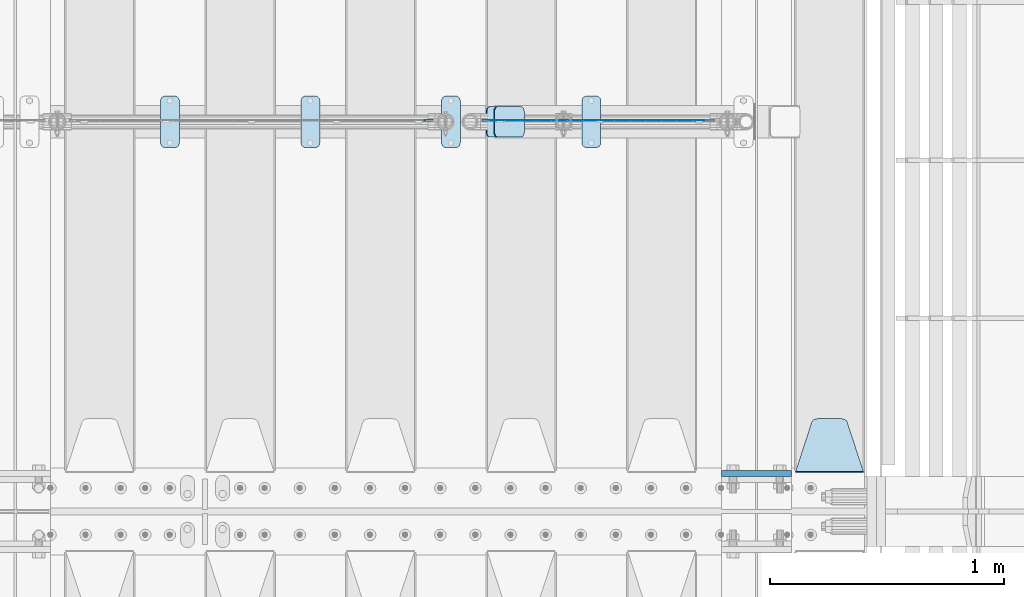
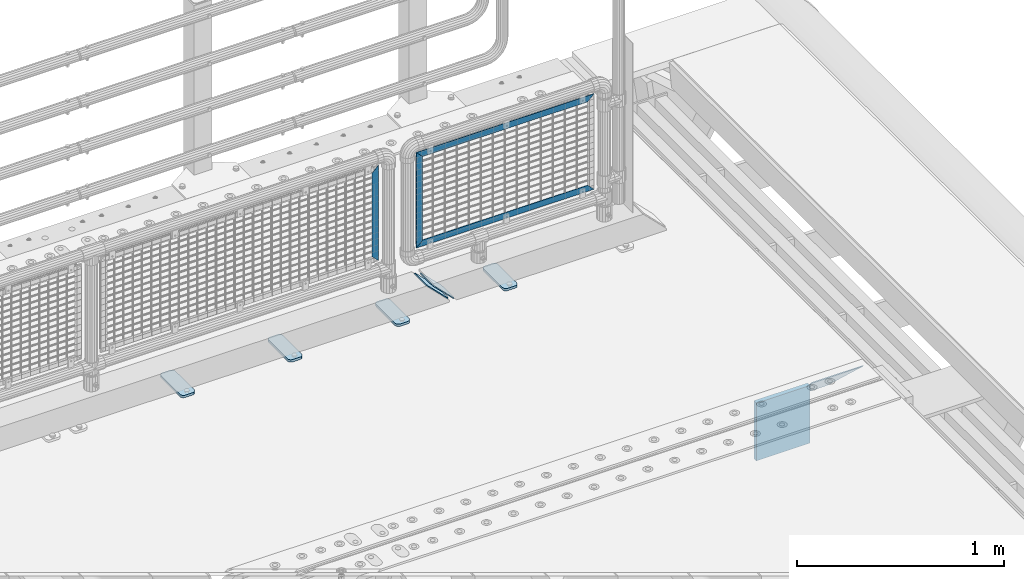
# One storey, part 222 of 240: 12 plates.
"""IFC2X3 building model written with IfcOpenShell, lengths in millimetres."""

from ifc_helpers import new_model, si_unit, frame, origin_with_axes, place, context, subcontext, project, spatial, faceted_brep, material, type_object, element, save


model = new_model("IFC2X3")

# Units and contexts
model_context = context("Model", 3, precision=1e-05, world=origin_with_axes())
body_context = subcontext(model_context, "Body", "Model", "MODEL_VIEW")
ifc_project = project(units=[si_unit("LENGTHUNIT", "METRE", prefix="MILLI"), si_unit("AREAUNIT", "SQUARE_METRE"), si_unit("VOLUMEUNIT", "CUBIC_METRE"), si_unit("MASSUNIT", "GRAM", prefix="KILO"), si_unit("TIMEUNIT", "SECOND"), si_unit("PLANEANGLEUNIT", "RADIAN"), si_unit("SOLIDANGLEUNIT", "STERADIAN"), si_unit("THERMODYNAMICTEMPERATUREUNIT", "DEGREE_CELSIUS"), si_unit("LUMINOUSINTENSITYUNIT", "LUMEN")], contexts=[model_context])

# Site, building, storey
site_placement = place(None, origin_with_axes())
site = spatial("IfcSite", under=ifc_project, at=site_placement, CompositionType="ELEMENT")
building_placement = place(site_placement, origin_with_axes())
building = spatial("IfcBuilding", under=site, at=building_placement, Name="Standard", CompositionType="ELEMENT")
storey_placement = place(building_placement, origin_with_axes())
storey = spatial("IfcBuildingStorey", under=building, at=storey_placement, Name="Undefined", CompositionType="ELEMENT", Elevation=0.0)

# Plates
ifc_material_1 = material(Name="STEEL/S355N")
plate_type_1 = type_object("IfcPlateType", PredefinedType="NOTDEFINED")
plate_1_placement = place(storey_placement, frame((55855.0, 33162.5, -340.000000000044), z_axis=(0.0, 0.0, 1.0), x_axis=(1.0, 0.0, 0.0)))
element("IfcPlate", 1, at=plate_1_placement, inside=storey, type_object=plate_type_1, material=ifc_material_1, context=body_context, shape_type="Brep", body=[
    faceted_brep([(0.0, -12.5, 0.0), (9.31322574615479e-10, -12.5, 340.0), (9.31322574615479e-10, 12.5, 340.0), (0.0, 12.5, 0.0), (300.0, -12.5, 340.0), (300.0, 12.5, 340.0), (300.0, -12.5, 0.0), (300.0, 12.5, 0.0)], [[[0, 1, 2, 3]], [[1, 4, 5, 2]], [[4, 6, 7, 5]], [[6, 0, 3, 7]], [[5, 7, 3, 2]], [[6, 4, 1, 0]]]),
])
plate_type_2 = type_object("IfcPlateType", PredefinedType="NOTDEFINED")
plate_2_placement = place(storey_placement, frame((56462.0, 33168.232233047, -1.76776695296758), z_axis=(0.0, 0.707106781186547, -0.707106781186548), x_axis=(-1.0, 0.0, 0.0)))
element("IfcPlate", 2, at=plate_2_placement, inside=storey, type_object=plate_type_2, material=ifc_material_1, context=body_context, shape_type="Brep", body=[
    faceted_brep([(0.0, -2.5, 0.0), (69.345504679477, -2.50000000000364, 300.171731424827), (69.345504679477, 2.49999999999636, 300.171731424827), (0.0, 2.5, 0.0), (70.927406119954, -2.50000000000364, 304.897442415397), (70.927406119954, 2.49999999999636, 304.897442415397), (73.3818627772271, -2.50000000000728, 309.234538108525), (73.3818627772271, 2.49999999999636, 309.234538108529), (76.6187032999587, -2.50000000000728, 313.023683126099), (76.6187032999587, 2.49999999999636, 313.023683126103), (80.5190132705029, -2.50000000000364, 316.125672595368), (80.5190132705029, 2.49999999999636, 316.125672595368), (84.9395038596849, -2.50000000000364, 318.426546230472), (84.9395038596849, 2.49999999999636, 318.426546230472), (89.7177759439219, -2.5, 319.841774983277), (89.7177759439219, 2.49999999999636, 319.841774983273), (94.6782862926484, -2.50000000000364, 320.319366455074), (94.6782862926484, 2.49999999999636, 320.319366455074), (195.321713707352, -2.50000000000364, 320.319366455074), (195.321713707352, 2.49999999999636, 320.319366455074), (200.282224056078, -2.50000000000364, 319.841774983273), (200.282224056078, 2.49999999999636, 319.841774983273), (205.060496140315, -2.50000000000364, 318.426546230472), (205.060496140315, 2.49999999999636, 318.426546230472), (209.480986729497, -2.50000000000364, 316.125672595368), (209.480986729497, 2.49999999999636, 316.125672595368), (213.381296700041, -2.50000000000728, 313.023683126099), (213.381296700041, 2.49999999999272, 313.023683126099), (216.618137222766, -2.50000000000364, 309.234538108522), (216.618137222766, 2.49999999999636, 309.234538108522), (219.072593880039, -2.50000000000364, 304.897442415397), (219.072593880039, 2.49999999999636, 304.897442415397), (220.654495320523, -2.50000000000364, 300.171731424827), (220.654495320523, 2.49999999999636, 300.171731424827), (290.0, -2.50000000000364, -3.63797880709171e-12), (290.0, 2.49999999999636, -3.63797880709171e-12)], [[[0, 1, 2, 3]], [[1, 4, 5, 2]], [[4, 6, 7, 5]], [[6, 8, 9, 7]], [[8, 10, 11, 9]], [[10, 12, 13, 11]], [[12, 14, 15, 13]], [[14, 16, 17, 15]], [[16, 18, 19, 17]], [[18, 20, 21, 19]], [[20, 22, 23, 21]], [[22, 24, 25, 23]], [[24, 26, 27, 25]], [[26, 28, 29, 27]], [[28, 30, 31, 29]], [[30, 32, 33, 31]], [[32, 34, 35, 33]], [[34, 0, 3, 35]], [[5, 7, 9, 11, 13, 15, 17, 19, 21, 23, 25, 27, 29, 31, 33, 35, 3, 2]], [[34, 32, 30, 28, 26, 24, 22, 20, 18, 16, 14, 12, 10, 8, 6, 4, 1, 0]]]),
])
ifc_material_2 = material(Name="STEEL/S355J2")
plate_type_3 = type_object("IfcPlateType", PredefinedType="NOTDEFINED")
plate_3_placement = place(storey_placement, frame((54060.0, 34774.5, 21.0199999999977), z_axis=(1.0, 0.0, 0.0), x_axis=(0.0, -1.0, 0.0)))
element("IfcPlate", 3, at=plate_3_placement, inside=storey, type_object=plate_type_3, material=ifc_material_2, context=body_context, shape_type="Brep", body=[
    faceted_brep([(0.0, -7.0, 20.0), (0.0, -7.0, 60.0), (0.0, 7.0, 60.0), (0.0, 7.0, 20.0), (0.384294391937146, -7.0, 63.9018064403208), (0.384294391937146, 7.0, 63.9018064403208), (1.52240934977453, -7.0, 67.6536686473046), (1.52240934977453, 7.0, 67.6536686473046), (3.37060775394639, -7.0, 71.1114046603907), (3.37060775394639, 7.0, 71.1114046603907), (5.85786437626666, -7.0, 74.1421356237333), (5.85786437626666, 7.0, 74.1421356237333), (8.88859533960931, -7.0, 76.6293922460536), (8.88859533960931, 7.0, 76.6293922460536), (12.3463313526954, -7.0, 78.4775906502255), (12.3463313526954, 7.0, 78.4775906502255), (16.0981935596792, -7.0, 79.6157056080629), (16.0981935596792, 7.0, 79.6157056080629), (20.0, -7.0, 80.0), (20.0, 7.0, 80.0), (200.0, -7.0, 80.0), (200.0, 7.0, 80.0), (203.901806440321, -7.0, 79.6157056080629), (203.901806440321, 7.0, 79.6157056080629), (207.653668647305, -7.0, 78.4775906502255), (207.653668647305, 7.0, 78.4775906502255), (211.111404660391, -7.0, 76.6293922460536), (211.111404660391, 7.0, 76.6293922460536), (214.142135623733, -7.0, 74.1421356237333), (214.142135623733, 7.0, 74.1421356237333), (216.629392246054, -7.0, 71.1114046603907), (216.629392246054, 7.0, 71.1114046603907), (218.477590650225, -7.0, 67.6536686473046), (218.477590650225, 7.0, 67.6536686473046), (219.615705608063, -7.0, 63.9018064403208), (219.615705608063, 7.0, 63.9018064403208), (220.0, -7.0, 60.0), (220.0, 7.0, 60.0), (220.0, -7.0, 20.0), (220.0, 7.0, 20.0), (219.615705608063, -7.0, 16.0981935596792), (219.615705608063, 7.0, 16.0981935596792), (218.477590650225, -7.0, 12.3463313526954), (218.477590650225, 7.0, 12.3463313526954), (216.629392246054, -7.0, 8.88859533960931), (216.629392246054, 7.0, 8.88859533960931), (214.142135623733, -7.0, 5.85786437626666), (214.142135623733, 7.0, 5.85786437626666), (211.111404660391, -7.0, 3.37060775394639), (211.111404660391, 7.0, 3.37060775394639), (207.653668647305, -7.0, 1.52240934977453), (207.653668647305, 7.0, 1.52240934977453), (203.901806440321, -7.0, 0.384294391937146), (203.901806440321, 7.0, 0.384294391937146), (200.0, -7.0, 0.0), (200.0, 7.0, 0.0), (20.0, -7.0, 0.0), (20.0, 7.0, 0.0), (16.0981935596792, -7.0, 0.384294391937146), (16.0981935596792, 7.0, 0.384294391937146), (12.3463313526954, -7.0, 1.52240934977453), (12.3463313526954, 7.0, 1.52240934977453), (8.88859533960931, -7.0, 3.37060775394639), (8.88859533960931, 7.0, 3.37060775394639), (5.85786437626666, -7.0, 5.85786437626666), (5.85786437626666, 7.0, 5.85786437626666), (3.37060775394639, -7.0, 8.88859533960931), (3.37060775394639, 7.0, 8.88859533960931), (1.52240934977453, -7.0, 12.3463313526954), (1.52240934977453, 7.0, 12.3463313526954), (0.384294391937146, -7.0, 16.0981935596792), (0.384294391937146, 7.0, 16.0981935596792)], [[[0, 1, 2, 3]], [[1, 4, 5, 2]], [[4, 6, 7, 5]], [[6, 8, 9, 7]], [[8, 10, 11, 9]], [[10, 12, 13, 11]], [[12, 14, 15, 13]], [[14, 16, 17, 15]], [[16, 18, 19, 17]], [[18, 20, 21, 19]], [[20, 22, 23, 21]], [[22, 24, 25, 23]], [[24, 26, 27, 25]], [[26, 28, 29, 27]], [[28, 30, 31, 29]], [[30, 32, 33, 31]], [[32, 34, 35, 33]], [[34, 36, 37, 35]], [[36, 38, 39, 37]], [[38, 40, 41, 39]], [[40, 42, 43, 41]], [[42, 44, 45, 43]], [[44, 46, 47, 45]], [[46, 48, 49, 47]], [[48, 50, 51, 49]], [[50, 52, 53, 51]], [[52, 54, 55, 53]], [[54, 56, 57, 55]], [[56, 58, 59, 57]], [[58, 60, 61, 59]], [[60, 62, 63, 61]], [[62, 64, 65, 63]], [[64, 66, 67, 65]], [[66, 68, 69, 67]], [[68, 70, 71, 69]], [[70, 0, 3, 71]], [[5, 7, 9, 11, 13, 15, 17, 19, 21, 23, 25, 27, 29, 31, 33, 35, 37, 39, 41, 43, 45, 47, 49, 51, 53, 55, 57, 59, 61, 63, 65, 67, 69, 71, 3, 2]], [[70, 68, 66, 64, 62, 60, 58, 56, 54, 52, 50, 48, 46, 44, 42, 40, 38, 36, 34, 32, 30, 28, 26, 24, 22, 20, 18, 16, 14, 12, 10, 8, 6, 4, 1, 0]]]),
])
plate_4_placement = place(storey_placement, frame((53460.0, 34774.5, 21.0199999999977), z_axis=(1.0, 0.0, 0.0), x_axis=(0.0, -1.0, 0.0)))
element("IfcPlate", 4, at=plate_4_placement, inside=storey, type_object=plate_type_3, material=ifc_material_2, context=body_context, shape_type="Brep", body=[
    faceted_brep([(0.0, -7.0, 20.0), (0.0, -7.0, 60.0), (0.0, 7.0, 60.0), (0.0, 7.0, 20.0), (0.384294391937146, -7.0, 63.9018064403208), (0.384294391937146, 7.0, 63.9018064403208), (1.52240934977453, -7.0, 67.6536686473046), (1.52240934977453, 7.0, 67.6536686473046), (3.37060775394639, -7.0, 71.1114046603907), (3.37060775394639, 7.0, 71.1114046603907), (5.85786437626666, -7.0, 74.1421356237333), (5.85786437626666, 7.0, 74.1421356237333), (8.88859533960931, -7.0, 76.6293922460536), (8.88859533960931, 7.0, 76.6293922460536), (12.3463313526954, -7.0, 78.4775906502255), (12.3463313526954, 7.0, 78.4775906502255), (16.0981935596792, -7.0, 79.6157056080629), (16.0981935596792, 7.0, 79.6157056080629), (20.0, -7.0, 80.0), (20.0, 7.0, 80.0), (200.0, -7.0, 80.0), (200.0, 7.0, 80.0), (203.901806440321, -7.0, 79.6157056080629), (203.901806440321, 7.0, 79.6157056080629), (207.653668647305, -7.0, 78.4775906502255), (207.653668647305, 7.0, 78.4775906502255), (211.111404660391, -7.0, 76.6293922460536), (211.111404660391, 7.0, 76.6293922460536), (214.142135623733, -7.0, 74.1421356237333), (214.142135623733, 7.0, 74.1421356237333), (216.629392246054, -7.0, 71.1114046603907), (216.629392246054, 7.0, 71.1114046603907), (218.477590650225, -7.0, 67.6536686473046), (218.477590650225, 7.0, 67.6536686473046), (219.615705608063, -7.0, 63.9018064403208), (219.615705608063, 7.0, 63.9018064403208), (220.0, -7.0, 60.0), (220.0, 7.0, 60.0), (220.0, -7.0, 20.0), (220.0, 7.0, 20.0), (219.615705608063, -7.0, 16.0981935596792), (219.615705608063, 7.0, 16.0981935596792), (218.477590650225, -7.0, 12.3463313526954), (218.477590650225, 7.0, 12.3463313526954), (216.629392246054, -7.0, 8.88859533960931), (216.629392246054, 7.0, 8.88859533960931), (214.142135623733, -7.0, 5.85786437626666), (214.142135623733, 7.0, 5.85786437626666), (211.111404660391, -7.0, 3.37060775394639), (211.111404660391, 7.0, 3.37060775394639), (207.653668647305, -7.0, 1.52240934977453), (207.653668647305, 7.0, 1.52240934977453), (203.901806440321, -7.0, 0.384294391937146), (203.901806440321, 7.0, 0.384294391937146), (200.0, -7.0, 0.0), (200.0, 7.0, 0.0), (20.0, -7.0, 0.0), (20.0, 7.0, 0.0), (16.0981935596792, -7.0, 0.384294391937146), (16.0981935596792, 7.0, 0.384294391937146), (12.3463313526954, -7.0, 1.52240934977453), (12.3463313526954, 7.0, 1.52240934977453), (8.88859533960931, -7.0, 3.37060775394639), (8.88859533960931, 7.0, 3.37060775394639), (5.85786437626666, -7.0, 5.85786437626666), (5.85786437626666, 7.0, 5.85786437626666), (3.37060775394639, -7.0, 8.88859533960931), (3.37060775394639, 7.0, 8.88859533960931), (1.52240934977453, -7.0, 12.3463313526954), (1.52240934977453, 7.0, 12.3463313526954), (0.384294391937146, -7.0, 16.0981935596792), (0.384294391937146, 7.0, 16.0981935596792)], [[[0, 1, 2, 3]], [[1, 4, 5, 2]], [[4, 6, 7, 5]], [[6, 8, 9, 7]], [[8, 10, 11, 9]], [[10, 12, 13, 11]], [[12, 14, 15, 13]], [[14, 16, 17, 15]], [[16, 18, 19, 17]], [[18, 20, 21, 19]], [[20, 22, 23, 21]], [[22, 24, 25, 23]], [[24, 26, 27, 25]], [[26, 28, 29, 27]], [[28, 30, 31, 29]], [[30, 32, 33, 31]], [[32, 34, 35, 33]], [[34, 36, 37, 35]], [[36, 38, 39, 37]], [[38, 40, 41, 39]], [[40, 42, 43, 41]], [[42, 44, 45, 43]], [[44, 46, 47, 45]], [[46, 48, 49, 47]], [[48, 50, 51, 49]], [[50, 52, 53, 51]], [[52, 54, 55, 53]], [[54, 56, 57, 55]], [[56, 58, 59, 57]], [[58, 60, 61, 59]], [[60, 62, 63, 61]], [[62, 64, 65, 63]], [[64, 66, 67, 65]], [[66, 68, 69, 67]], [[68, 70, 71, 69]], [[70, 0, 3, 71]], [[5, 7, 9, 11, 13, 15, 17, 19, 21, 23, 25, 27, 29, 31, 33, 35, 37, 39, 41, 43, 45, 47, 49, 51, 53, 55, 57, 59, 61, 63, 65, 67, 69, 71, 3, 2]], [[70, 68, 66, 64, 62, 60, 58, 56, 54, 52, 50, 48, 46, 44, 42, 40, 38, 36, 34, 32, 30, 28, 26, 24, 22, 20, 18, 16, 14, 12, 10, 8, 6, 4, 1, 0]]]),
])
plate_5_placement = place(storey_placement, frame((54660.0, 34774.5, 21.0199999999977), z_axis=(1.0, 0.0, 0.0), x_axis=(0.0, -1.0, 0.0)))
element("IfcPlate", 5, at=plate_5_placement, inside=storey, type_object=plate_type_3, material=ifc_material_2, context=body_context, shape_type="Brep", body=[
    faceted_brep([(0.0, -7.0, 20.0), (0.0, -7.0, 60.0), (0.0, 7.0, 60.0), (0.0, 7.0, 20.0), (0.384294391937146, -7.0, 63.9018064403208), (0.384294391937146, 7.0, 63.9018064403208), (1.52240934977453, -7.0, 67.6536686473046), (1.52240934977453, 7.0, 67.6536686473046), (3.37060775394639, -7.0, 71.1114046603907), (3.37060775394639, 7.0, 71.1114046603907), (5.85786437626666, -7.0, 74.1421356237333), (5.85786437626666, 7.0, 74.1421356237333), (8.88859533960931, -7.0, 76.6293922460536), (8.88859533960931, 7.0, 76.6293922460536), (12.3463313526954, -7.0, 78.4775906502255), (12.3463313526954, 7.0, 78.4775906502255), (16.0981935596792, -7.0, 79.6157056080629), (16.0981935596792, 7.0, 79.6157056080629), (20.0, -7.0, 80.0), (20.0, 7.0, 80.0), (200.0, -7.0, 80.0), (200.0, 7.0, 80.0), (203.901806440321, -7.0, 79.6157056080629), (203.901806440321, 7.0, 79.6157056080629), (207.653668647305, -7.0, 78.4775906502255), (207.653668647305, 7.0, 78.4775906502255), (211.111404660391, -7.0, 76.6293922460536), (211.111404660391, 7.0, 76.6293922460536), (214.142135623733, -7.0, 74.1421356237333), (214.142135623733, 7.0, 74.1421356237333), (216.629392246054, -7.0, 71.1114046603907), (216.629392246054, 7.0, 71.1114046603907), (218.477590650225, -7.0, 67.6536686473046), (218.477590650225, 7.0, 67.6536686473046), (219.615705608063, -7.0, 63.9018064403208), (219.615705608063, 7.0, 63.9018064403208), (220.0, -7.0, 60.0), (220.0, 7.0, 60.0), (220.0, -7.0, 20.0), (220.0, 7.0, 20.0), (219.615705608063, -7.0, 16.0981935596792), (219.615705608063, 7.0, 16.0981935596792), (218.477590650225, -7.0, 12.3463313526954), (218.477590650225, 7.0, 12.3463313526954), (216.629392246054, -7.0, 8.88859533960931), (216.629392246054, 7.0, 8.88859533960931), (214.142135623733, -7.0, 5.85786437626666), (214.142135623733, 7.0, 5.85786437626666), (211.111404660391, -7.0, 3.37060775394639), (211.111404660391, 7.0, 3.37060775394639), (207.653668647305, -7.0, 1.52240934977453), (207.653668647305, 7.0, 1.52240934977453), (203.901806440321, -7.0, 0.384294391937146), (203.901806440321, 7.0, 0.384294391937146), (200.0, -7.0, 0.0), (200.0, 7.0, 0.0), (20.0, -7.0, 0.0), (20.0, 7.0, 0.0), (16.0981935596792, -7.0, 0.384294391937146), (16.0981935596792, 7.0, 0.384294391937146), (12.3463313526954, -7.0, 1.52240934977453), (12.3463313526954, 7.0, 1.52240934977453), (8.88859533960931, -7.0, 3.37060775394639), (8.88859533960931, 7.0, 3.37060775394639), (5.85786437626666, -7.0, 5.85786437626666), (5.85786437626666, 7.0, 5.85786437626666), (3.37060775394639, -7.0, 8.88859533960931), (3.37060775394639, 7.0, 8.88859533960931), (1.52240934977453, -7.0, 12.3463313526954), (1.52240934977453, 7.0, 12.3463313526954), (0.384294391937146, -7.0, 16.0981935596792), (0.384294391937146, 7.0, 16.0981935596792)], [[[0, 1, 2, 3]], [[1, 4, 5, 2]], [[4, 6, 7, 5]], [[6, 8, 9, 7]], [[8, 10, 11, 9]], [[10, 12, 13, 11]], [[12, 14, 15, 13]], [[14, 16, 17, 15]], [[16, 18, 19, 17]], [[18, 20, 21, 19]], [[20, 22, 23, 21]], [[22, 24, 25, 23]], [[24, 26, 27, 25]], [[26, 28, 29, 27]], [[28, 30, 31, 29]], [[30, 32, 33, 31]], [[32, 34, 35, 33]], [[34, 36, 37, 35]], [[36, 38, 39, 37]], [[38, 40, 41, 39]], [[40, 42, 43, 41]], [[42, 44, 45, 43]], [[44, 46, 47, 45]], [[46, 48, 49, 47]], [[48, 50, 51, 49]], [[50, 52, 53, 51]], [[52, 54, 55, 53]], [[54, 56, 57, 55]], [[56, 58, 59, 57]], [[58, 60, 61, 59]], [[60, 62, 63, 61]], [[62, 64, 65, 63]], [[64, 66, 67, 65]], [[66, 68, 69, 67]], [[68, 70, 71, 69]], [[70, 0, 3, 71]], [[5, 7, 9, 11, 13, 15, 17, 19, 21, 23, 25, 27, 29, 31, 33, 35, 37, 39, 41, 43, 45, 47, 49, 51, 53, 55, 57, 59, 61, 63, 65, 67, 69, 71, 3, 2]], [[70, 68, 66, 64, 62, 60, 58, 56, 54, 52, 50, 48, 46, 44, 42, 40, 38, 36, 34, 32, 30, 28, 26, 24, 22, 20, 18, 16, 14, 12, 10, 8, 6, 4, 1, 0]]]),
])
plate_6_placement = place(storey_placement, frame((55260.0, 34774.5, 21.0199999999977), z_axis=(1.0, 0.0, 0.0), x_axis=(0.0, -1.0, 0.0)))
element("IfcPlate", 6, at=plate_6_placement, inside=storey, type_object=plate_type_3, material=ifc_material_2, context=body_context, shape_type="Brep", body=[
    faceted_brep([(0.0, -7.0, 20.0), (0.0, -7.0, 60.0), (0.0, 7.0, 60.0), (0.0, 7.0, 20.0), (0.384294391937146, -7.0, 63.9018064403208), (0.384294391937146, 7.0, 63.9018064403208), (1.52240934977453, -7.0, 67.6536686473046), (1.52240934977453, 7.0, 67.6536686473046), (3.37060775394639, -7.0, 71.1114046603907), (3.37060775394639, 7.0, 71.1114046603907), (5.85786437626666, -7.0, 74.1421356237333), (5.85786437626666, 7.0, 74.1421356237333), (8.88859533960931, -7.0, 76.6293922460536), (8.88859533960931, 7.0, 76.6293922460536), (12.3463313526954, -7.0, 78.4775906502255), (12.3463313526954, 7.0, 78.4775906502255), (16.0981935596792, -7.0, 79.6157056080629), (16.0981935596792, 7.0, 79.6157056080629), (20.0, -7.0, 80.0), (20.0, 7.0, 80.0), (200.0, -7.0, 80.0), (200.0, 7.0, 80.0), (203.901806440321, -7.0, 79.6157056080629), (203.901806440321, 7.0, 79.6157056080629), (207.653668647305, -7.0, 78.4775906502255), (207.653668647305, 7.0, 78.4775906502255), (211.111404660391, -7.0, 76.6293922460536), (211.111404660391, 7.0, 76.6293922460536), (214.142135623733, -7.0, 74.1421356237333), (214.142135623733, 7.0, 74.1421356237333), (216.629392246054, -7.0, 71.1114046603907), (216.629392246054, 7.0, 71.1114046603907), (218.477590650225, -7.0, 67.6536686473046), (218.477590650225, 7.0, 67.6536686473046), (219.615705608063, -7.0, 63.9018064403208), (219.615705608063, 7.0, 63.9018064403208), (220.0, -7.0, 60.0), (220.0, 7.0, 60.0), (220.0, -7.0, 20.0), (220.0, 7.0, 20.0), (219.615705608063, -7.0, 16.0981935596792), (219.615705608063, 7.0, 16.0981935596792), (218.477590650225, -7.0, 12.3463313526954), (218.477590650225, 7.0, 12.3463313526954), (216.629392246054, -7.0, 8.88859533960931), (216.629392246054, 7.0, 8.88859533960931), (214.142135623733, -7.0, 5.85786437626666), (214.142135623733, 7.0, 5.85786437626666), (211.111404660391, -7.0, 3.37060775394639), (211.111404660391, 7.0, 3.37060775394639), (207.653668647305, -7.0, 1.52240934977453), (207.653668647305, 7.0, 1.52240934977453), (203.901806440321, -7.0, 0.384294391937146), (203.901806440321, 7.0, 0.384294391937146), (200.0, -7.0, 0.0), (200.0, 7.0, 0.0), (20.0, -7.0, 0.0), (20.0, 7.0, 0.0), (16.0981935596792, -7.0, 0.384294391937146), (16.0981935596792, 7.0, 0.384294391937146), (12.3463313526954, -7.0, 1.52240934977453), (12.3463313526954, 7.0, 1.52240934977453), (8.88859533960931, -7.0, 3.37060775394639), (8.88859533960931, 7.0, 3.37060775394639), (5.85786437626666, -7.0, 5.85786437626666), (5.85786437626666, 7.0, 5.85786437626666), (3.37060775394639, -7.0, 8.88859533960931), (3.37060775394639, 7.0, 8.88859533960931), (1.52240934977453, -7.0, 12.3463313526954), (1.52240934977453, 7.0, 12.3463313526954), (0.384294391937146, -7.0, 16.0981935596792), (0.384294391937146, 7.0, 16.0981935596792)], [[[0, 1, 2, 3]], [[1, 4, 5, 2]], [[4, 6, 7, 5]], [[6, 8, 9, 7]], [[8, 10, 11, 9]], [[10, 12, 13, 11]], [[12, 14, 15, 13]], [[14, 16, 17, 15]], [[16, 18, 19, 17]], [[18, 20, 21, 19]], [[20, 22, 23, 21]], [[22, 24, 25, 23]], [[24, 26, 27, 25]], [[26, 28, 29, 27]], [[28, 30, 31, 29]], [[30, 32, 33, 31]], [[32, 34, 35, 33]], [[34, 36, 37, 35]], [[36, 38, 39, 37]], [[38, 40, 41, 39]], [[40, 42, 43, 41]], [[42, 44, 45, 43]], [[44, 46, 47, 45]], [[46, 48, 49, 47]], [[48, 50, 51, 49]], [[50, 52, 53, 51]], [[52, 54, 55, 53]], [[54, 56, 57, 55]], [[56, 58, 59, 57]], [[58, 60, 61, 59]], [[60, 62, 63, 61]], [[62, 64, 65, 63]], [[64, 66, 67, 65]], [[66, 68, 69, 67]], [[68, 70, 71, 69]], [[70, 0, 3, 71]], [[5, 7, 9, 11, 13, 15, 17, 19, 21, 23, 25, 27, 29, 31, 33, 35, 37, 39, 41, 43, 45, 47, 49, 51, 53, 55, 57, 59, 61, 63, 65, 67, 69, 71, 3, 2]], [[70, 68, 66, 64, 62, 60, 58, 56, 54, 52, 50, 48, 46, 44, 42, 40, 38, 36, 34, 32, 30, 28, 26, 24, 22, 20, 18, 16, 14, 12, 10, 8, 6, 4, 1, 0]]]),
])
plate_type_4 = type_object("IfcPlateType", PredefinedType="NOTDEFINED")
plate_7_placement = place(storey_placement, frame((54852.192418479, 34729.5, 166.254400376559), z_axis=(0.707410512925779, 0.0, -0.70680291892584), x_axis=(0.0, -1.0, 0.0)))
element("IfcPlate", 7, at=plate_7_placement, inside=storey, type_object=plate_type_4, material=ifc_material_2, context=body_context, shape_type="Brep", body=[
    faceted_brep([(0.0, -2.5, 20.0), (0.0, -2.5, 158.926651000977), (0.0, 2.50000000000728, 158.926651000969), (0.0, 2.5, 19.9999999999927), (0.384294391937146, -2.50000000000728, 162.828457441297), (0.384294391937146, 2.5, 162.828457441297), (1.52240934977453, -2.5, 166.580319648274), (1.52240934977453, 2.50000000000728, 166.580319648274), (3.37060775394639, -2.5, 170.038055661367), (3.37060775394639, 2.5, 170.038055661367), (5.85786437626666, -2.49999999999272, 173.068786624703), (5.85786437626666, 2.5, 173.068786624703), (8.88859533960931, -2.5, 175.556043247023), (8.88859533960931, 2.50000000000728, 175.556043247023), (12.3463313526954, -2.5, 177.404241651195), (12.3463313526954, 2.50000000000728, 177.404241651195), (16.0981935596792, -2.5, 178.542356609039), (16.0981935596792, 2.50000000000728, 178.542356609039), (20.0, -2.5, 178.926651000977), (20.0, 2.5, 178.926651000977), (110.0, -2.5, 178.926651000977), (110.0, 2.5, 178.926651000977), (113.901806440321, -2.5, 178.542356609039), (113.901806440321, 2.50000000000728, 178.542356609039), (117.653668647305, -2.5, 177.404241651195), (117.653668647305, 2.50000000000728, 177.404241651195), (121.111404660391, -2.5, 175.556043247023), (121.111404660391, 2.50000000000728, 175.556043247023), (124.142135623733, -2.49999999999272, 173.068786624703), (124.142135623733, 2.5, 173.068786624703), (126.629392246054, -2.5, 170.038055661367), (126.629392246054, 2.5, 170.038055661367), (128.477590650225, -2.5, 166.580319648274), (128.477590650225, 2.50000000000728, 166.580319648274), (129.615705608063, -2.50000000000728, 162.828457441297), (129.615705608063, 2.5, 162.828457441297), (130.0, -2.5, 158.926651000977), (130.0, 2.50000000000728, 158.926651000969), (130.0, -2.5, 20.0), (130.0, 2.5, 19.9999999999927), (129.615705608063, -2.5, 16.0981935596719), (129.615705608063, 2.50000000000728, 16.0981935596719), (128.477590650225, -2.50000000000728, 12.3463313527027), (128.477590650225, 2.5, 12.3463313526954), (126.629392246054, -2.49999999999272, 8.88859533960931), (126.629392246054, 2.5, 8.88859533960931), (124.142135623733, -2.49999999999272, 5.85786437626666), (124.142135623733, 2.5, 5.85786437626666), (121.111404660391, -2.5, 3.37060775394639), (121.111404660391, 2.5, 3.37060775393911), (117.653668647305, -2.5, 1.52240934976726), (117.653668647305, 2.5, 1.52240934977453), (113.901806440321, -2.5, 0.38429439192987), (113.901806440321, 2.5, 0.38429439192987), (110.0, -2.5, 0.0), (110.0, 2.5, 0.0), (20.0, -2.5, 0.0), (20.0, 2.5, 0.0), (16.0981935596792, -2.5, 0.38429439192987), (16.0981935596792, 2.5, 0.38429439192987), (12.3463313526954, -2.5, 1.52240934976726), (12.3463313526954, 2.5, 1.52240934977453), (8.88859533960931, -2.5, 3.37060775394639), (8.88859533960931, 2.5, 3.37060775393911), (5.85786437626666, -2.49999999999272, 5.85786437626666), (5.85786437626666, 2.5, 5.85786437626666), (3.37060775394639, -2.49999999999272, 8.88859533960931), (3.37060775394639, 2.5, 8.88859533960931), (1.52240934977453, -2.5, 12.3463313526954), (1.52240934977453, 2.5, 12.3463313526954), (0.384294391937146, -2.5, 16.0981935596719), (0.384294391937146, 2.50000000000728, 16.0981935596719)], [[[0, 1, 2, 3]], [[1, 4, 5, 2]], [[4, 6, 7, 5]], [[6, 8, 9, 7]], [[8, 10, 11, 9]], [[10, 12, 13, 11]], [[12, 14, 15, 13]], [[14, 16, 17, 15]], [[16, 18, 19, 17]], [[18, 20, 21, 19]], [[20, 22, 23, 21]], [[22, 24, 25, 23]], [[24, 26, 27, 25]], [[26, 28, 29, 27]], [[28, 30, 31, 29]], [[30, 32, 33, 31]], [[32, 34, 35, 33]], [[34, 36, 37, 35]], [[36, 38, 39, 37]], [[38, 40, 41, 39]], [[40, 42, 43, 41]], [[42, 44, 45, 43]], [[44, 46, 47, 45]], [[46, 48, 49, 47]], [[48, 50, 51, 49]], [[50, 52, 53, 51]], [[52, 54, 55, 53]], [[54, 56, 57, 55]], [[56, 58, 59, 57]], [[58, 60, 61, 59]], [[60, 62, 63, 61]], [[62, 64, 65, 63]], [[64, 66, 67, 65]], [[66, 68, 69, 67]], [[68, 70, 71, 69]], [[70, 0, 3, 71]], [[5, 7, 9, 11, 13, 15, 17, 19, 21, 23, 25, 27, 29, 31, 33, 35, 37, 39, 41, 43, 45, 47, 49, 51, 53, 55, 57, 59, 61, 63, 65, 67, 69, 71, 3, 2]], [[70, 68, 66, 64, 62, 60, 58, 56, 54, 52, 50, 48, 46, 44, 42, 40, 38, 36, 34, 32, 30, 28, 26, 24, 22, 20, 18, 16, 14, 12, 10, 8, 6, 4, 1, 0]]]),
])
plate_8_placement = place(storey_placement, frame((54885.1214822168, 34729.5, 156.251454056255), z_axis=(0.707418377001898, 0.0, -0.706795048001895), x_axis=(0.0, -1.0, 0.0)))
element("IfcPlate", 8, at=plate_8_placement, inside=storey, type_object=plate_type_4, material=ifc_material_2, context=body_context, shape_type="Brep", body=[
    faceted_brep([(0.0, -2.5, 20.0), (0.0, -2.5, 158.926651000977), (0.0, 2.50000000000728, 158.926651000969), (0.0, 2.5, 19.9999999999927), (0.384294391937146, -2.50000000000728, 162.828457441297), (0.384294391937146, 2.5, 162.828457441297), (1.52240934977453, -2.5, 166.580319648274), (1.52240934977453, 2.50000000000728, 166.580319648274), (3.37060775394639, -2.5, 170.038055661367), (3.37060775394639, 2.5, 170.038055661367), (5.85786437626666, -2.49999999999272, 173.068786624703), (5.85786437626666, 2.5, 173.068786624703), (8.88859533960931, -2.5, 175.556043247023), (8.88859533960931, 2.50000000000728, 175.556043247023), (12.3463313526954, -2.5, 177.404241651195), (12.3463313526954, 2.50000000000728, 177.404241651195), (16.0981935596792, -2.5, 178.542356609039), (16.0981935596792, 2.50000000000728, 178.542356609039), (20.0, -2.5, 178.926651000977), (20.0, 2.5, 178.926651000977), (110.0, -2.5, 178.926651000977), (110.0, 2.5, 178.926651000977), (113.901806440321, -2.5, 178.542356609039), (113.901806440321, 2.50000000000728, 178.542356609039), (117.653668647305, -2.5, 177.404241651195), (117.653668647305, 2.50000000000728, 177.404241651195), (121.111404660391, -2.5, 175.556043247023), (121.111404660391, 2.50000000000728, 175.556043247023), (124.142135623733, -2.49999999999272, 173.068786624703), (124.142135623733, 2.5, 173.068786624703), (126.629392246054, -2.5, 170.038055661367), (126.629392246054, 2.5, 170.038055661367), (128.477590650225, -2.5, 166.580319648274), (128.477590650225, 2.50000000000728, 166.580319648274), (129.615705608063, -2.50000000000728, 162.828457441297), (129.615705608063, 2.5, 162.828457441297), (130.0, -2.5, 158.926651000977), (130.0, 2.50000000000728, 158.926651000969), (130.0, -2.5, 20.0), (130.0, 2.5, 19.9999999999927), (129.615705608063, -2.5, 16.0981935596719), (129.615705608063, 2.50000000000728, 16.0981935596719), (128.477590650225, -2.50000000000728, 12.3463313527027), (128.477590650225, 2.5, 12.3463313526954), (126.629392246054, -2.49999999999272, 8.88859533960931), (126.629392246054, 2.5, 8.88859533960931), (124.142135623733, -2.49999999999272, 5.85786437626666), (124.142135623733, 2.5, 5.85786437626666), (121.111404660391, -2.5, 3.37060775394639), (121.111404660391, 2.5, 3.37060775393911), (117.653668647305, -2.5, 1.52240934976726), (117.653668647305, 2.5, 1.52240934977453), (113.901806440321, -2.5, 0.38429439192987), (113.901806440321, 2.5, 0.38429439192987), (110.0, -2.5, 0.0), (110.0, 2.5, 0.0), (20.0, -2.5, 0.0), (20.0, 2.5, 0.0), (16.0981935596792, -2.5, 0.38429439192987), (16.0981935596792, 2.5, 0.38429439192987), (12.3463313526954, -2.5, 1.52240934976726), (12.3463313526954, 2.5, 1.52240934977453), (8.88859533960931, -2.5, 3.37060775394639), (8.88859533960931, 2.5, 3.37060775393911), (5.85786437626666, -2.49999999999272, 5.85786437626666), (5.85786437626666, 2.5, 5.85786437626666), (3.37060775394639, -2.49999999999272, 8.88859533960931), (3.37060775394639, 2.5, 8.88859533960931), (1.52240934977453, -2.5, 12.3463313526954), (1.52240934977453, 2.5, 12.3463313526954), (0.384294391937146, -2.5, 16.0981935596719), (0.384294391937146, 2.50000000000728, 16.0981935596719)], [[[0, 1, 2, 3]], [[1, 4, 5, 2]], [[4, 6, 7, 5]], [[6, 8, 9, 7]], [[8, 10, 11, 9]], [[10, 12, 13, 11]], [[12, 14, 15, 13]], [[14, 16, 17, 15]], [[16, 18, 19, 17]], [[18, 20, 21, 19]], [[20, 22, 23, 21]], [[22, 24, 25, 23]], [[24, 26, 27, 25]], [[26, 28, 29, 27]], [[28, 30, 31, 29]], [[30, 32, 33, 31]], [[32, 34, 35, 33]], [[34, 36, 37, 35]], [[36, 38, 39, 37]], [[38, 40, 41, 39]], [[40, 42, 43, 41]], [[42, 44, 45, 43]], [[44, 46, 47, 45]], [[46, 48, 49, 47]], [[48, 50, 51, 49]], [[50, 52, 53, 51]], [[52, 54, 55, 53]], [[54, 56, 57, 55]], [[56, 58, 59, 57]], [[58, 60, 61, 59]], [[60, 62, 63, 61]], [[62, 64, 65, 63]], [[64, 66, 67, 65]], [[66, 68, 69, 67]], [[68, 70, 71, 69]], [[70, 0, 3, 71]], [[5, 7, 9, 11, 13, 15, 17, 19, 21, 23, 25, 27, 29, 31, 33, 35, 37, 39, 41, 43, 45, 47, 49, 51, 53, 55, 57, 59, 61, 63, 65, 67, 69, 71, 3, 2]], [[70, 68, 66, 64, 62, 60, 58, 56, 54, 52, 50, 48, 46, 44, 42, 40, 38, 36, 34, 32, 30, 28, 26, 24, 22, 20, 18, 16, 14, 12, 10, 8, 6, 4, 1, 0]]]),
])
ifc_material_3 = material(Name="Misc_Undefined")
plate_type_5 = type_object("IfcPlateType", PredefinedType="NOTDEFINED")
plate_9_placement = place(storey_placement, frame((54588.4996874836, 34670.5, 879.52), z_axis=(0.707103624179501, 0.0, -0.707109938179499), x_axis=(0.707109938179525, 0.0, 0.707103624179475)))
element("IfcPlate", 9, at=plate_9_placement, inside=storey, type_object=plate_type_5, material=ifc_material_3, context=body_context, shape_type="Brep", body=[
    faceted_brep([(-7.27595761418343e-12, -1.49999999999272, 0.0), (-348.605163574233, -1.5, 348.602081298821), (-348.605163574233, 1.5, 348.602081298821), (0.0, 1.50000000000728, 0.0), (-348.605163574226, -1.5, 398.099334716797), (-348.605163574226, 1.5, 398.099334716797), (49.4976959228443, -1.5, -1.09139364212751e-10), (49.4976959228443, 1.5, -1.09139364212751e-10)], [[[0, 1, 2, 3]], [[1, 4, 5, 2]], [[4, 6, 7, 5]], [[6, 0, 3, 7]], [[5, 7, 3, 2]], [[6, 4, 1, 0]]]),
])
plate_10_placement = place(storey_placement, frame((54870.1100258824, 34670.4999645044, 879.520017263591), z_axis=(-0.707106781186548, 0.0, -0.707106781186548), x_axis=(-0.707106781186548, 0.0, 0.707106781186548)))
element("IfcPlate", 10, at=plate_10_placement, inside=storey, type_object=plate_type_5, material=ifc_material_3, context=body_context, shape_type="Brep", body=[
    faceted_brep([(-7.27595761418343e-12, -1.49999999999272, 0.0), (-348.603637695356, -1.50000000000728, 348.603668212891), (-348.603637695349, 1.49999999999272, 348.603668212883), (0.0, 1.50000000000728, 0.0), (-348.603637695356, -1.5, 398.101165771484), (-348.603637695363, 1.49999999999272, 398.101165771484), (49.4974975586083, -1.50000000000728, 2.18278728425503e-11), (49.497497558601, 1.49999999999272, 2.18278728425503e-11)], [[[0, 1, 2, 3]], [[1, 4, 5, 2]], [[4, 6, 7, 5]], [[6, 0, 3, 7]], [[5, 7, 3, 2]], [[6, 4, 1, 0]]]),
])
plate_11_placement = place(storey_placement, frame((54870.1100003336, 34670.4999883292, 386.520006105206), z_axis=(0.707106781186548, 0.0, -0.707106781186548), x_axis=(-0.707106781186548, 0.0, -0.707106781186548)))
element("IfcPlate", 11, at=plate_11_placement, inside=storey, type_object=plate_type_5, material=ifc_material_3, context=body_context, shape_type="Brep", body=[
    faceted_brep([(-7.27595761418343e-12, -1.49999999999272, 0.0), (-651.521057128906, -1.50000000000728, 651.521179199233), (-651.521057128906, 1.49999999999272, 651.521179199226), (0.0, 1.50000000000728, 0.0), (-651.521057128906, -1.50000000000728, 701.01867675782), (-651.521057128906, 1.49999999999272, 701.01867675782), (49.4974975586083, -1.50000000000728, 2.18278728425503e-11), (49.497497558601, 1.49999999999272, 2.18278728425503e-11)], [[[0, 1, 2, 3]], [[1, 4, 5, 2]], [[4, 6, 7, 5]], [[6, 0, 3, 7]], [[5, 7, 3, 2]], [[6, 4, 1, 0]]]),
])
plate_12_placement = place(storey_placement, frame((55826.4999993967, 34670.4997837706, 914.520000514841), z_axis=(-0.707106781186548, 0.0, 0.707106781186548), x_axis=(-0.707106781186548, 0.0, -0.707106781186548)))
element("IfcPlate", 12, at=plate_12_placement, inside=storey, type_object=plate_type_5, material=ifc_material_3, context=body_context, shape_type="Brep", body=[
    faceted_brep([(-7.27595761418343e-12, -1.49999999999272, 0.0), (701.018554687551, -1.5, 701.018615722664), (701.018554687544, 1.5, 701.018615722664), (0.0, 1.50000000000728, 0.0), (701.018554687544, -1.49999999999272, 651.52111816407), (701.018554687544, 1.50000000000728, 651.52111816407), (49.4974975586083, -1.50000000000728, 2.18278728425503e-11), (49.497497558601, 1.49999999999272, 2.18278728425503e-11)], [[[0, 1, 2, 3]], [[1, 4, 5, 2]], [[4, 6, 7, 5]], [[6, 0, 3, 7]], [[5, 7, 3, 2]], [[6, 4, 1, 0]]]),
])

save(model, "model.ifc")
